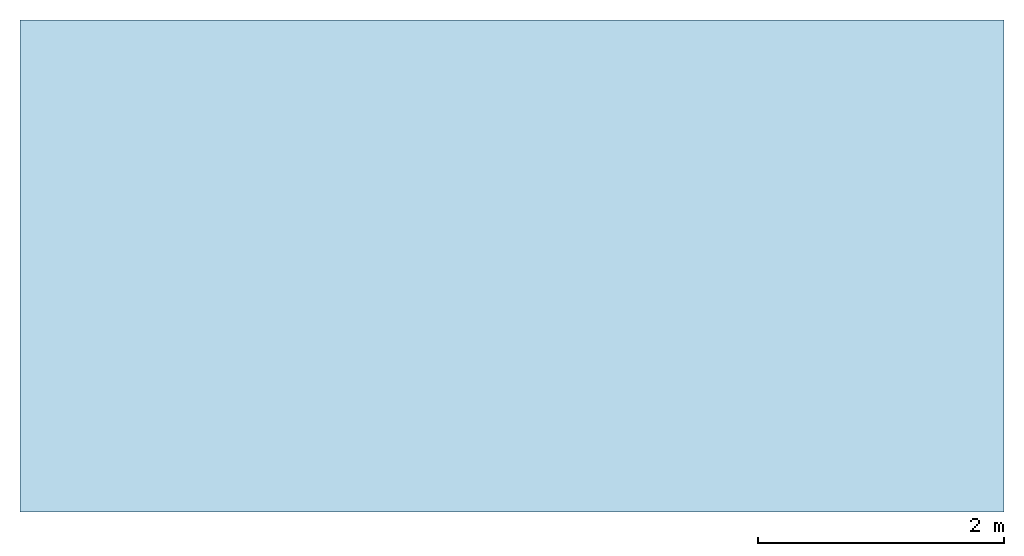
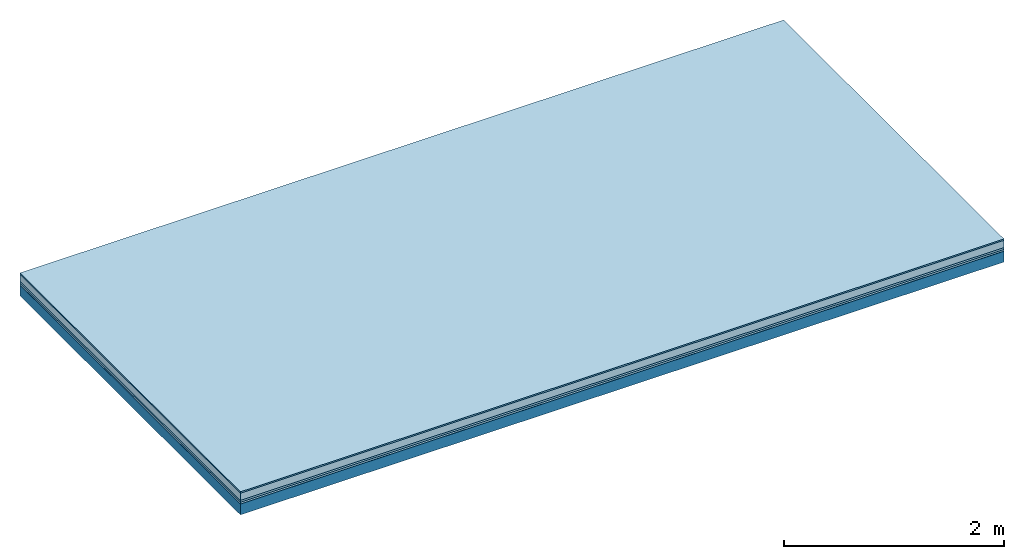
# One storey: 5 plates, 1 member, 1 element without a shape of its own.
"""IFC4 building model written with IfcOpenShell, lengths in metres."""

import ifcopenshell
import ifcopenshell.guid

model = None  # the IFC model being written
_history = None  # IfcOwnerHistory: only IFC2X3 demands one
_inside = {}  # id of a spatial element -> (the spatial element, [elements in it])
_under = {}  # id of a project, library or spatial element -> (it, [spatial elements below it])
_declared = {}  # id of a project -> (the project, [libraries it declares])
_typed = {}  # id of a type object -> (the type object, [elements of that type])
_made_of = {}  # id of a material, layer set ... -> (it, [elements and type objects made of it])


def new_model(schema):
    """Start an empty IFC model of exactly this schema.

    Asked for "IFC4X3", IfcOpenShell would pick the latest addendum, in which some entities
    have other attributes; the version numbers below select the first issue.
    IFC2X3 requires an IfcOwnerHistory on every rooted entity: one is made here for all.
    """
    global model, _history
    if schema == "IFC4X3":
        model = ifcopenshell.file(schema_version=(4, 3, 0, 0))
    else:
        model = ifcopenshell.file(schema=schema)
    _inside.clear()
    _under.clear()
    _declared.clear()
    _typed.clear()
    _made_of.clear()
    _history = None
    if model.schema == "IFC2X3":
        org = make("IfcOrganization", Name="unknown")
        user = make(
            "IfcPersonAndOrganization",
            ThePerson=make("IfcPerson", FamilyName="unknown"),
            TheOrganization=org,
        )
        app = make(
            "IfcApplication",
            ApplicationDeveloper=org,
            Version="unknown",
            ApplicationFullName="unknown",
            ApplicationIdentifier="unknown",
        )
        _history = make(
            "IfcOwnerHistory",
            OwningUser=user,
            OwningApplication=app,
            ChangeAction="ADDED",
            CreationDate=0,
        )
    return model


def make(cls, **values):
    """One entity of the class cls with the attributes given. An attribute that is None is left unset."""
    return model.create_entity(
        cls, **{name: value for name, value in values.items() if value is not None}
    )


def rooted(cls, **values):
    """An entity with a GlobalId (a new one), such as an element, a storey or a relation."""
    return make(cls, GlobalId=ifcopenshell.guid.new(), OwnerHistory=_history, **values)


def si_unit(unit_type, name, prefix=None):
    """IfcSIUnit, for example si_unit("LENGTHUNIT", "METRE", prefix="MILLI")."""
    return make("IfcSIUnit", UnitType=unit_type, Prefix=prefix, Name=name)


def derived_unit(unit_type, elements):
    """IfcDerivedUnit: a product of units, each with its exponent."""
    return make(
        "IfcDerivedUnit",
        Elements=[
            make("IfcDerivedUnitElement", Unit=unit, Exponent=power)
            for unit, power in elements
        ],
        UnitType=unit_type,
    )


def assignment(units):
    """IfcUnitAssignment: the units of a project."""
    return None if units is None else make("IfcUnitAssignment", Units=units)


def point(xyz):
    """IfcCartesianPoint."""
    return None if xyz is None else make("IfcCartesianPoint", Coordinates=xyz)


def direction(xyz):
    """IfcDirection."""
    return None if xyz is None else make("IfcDirection", DirectionRatios=xyz)


def frame(location, z_axis=None, x_axis=None):
    """IfcAxis2Placement3D, a coordinate frame: its origin and axes. An axis left out is left unset."""
    return make(
        "IfcAxis2Placement3D",
        Location=point(location),
        Axis=direction(z_axis),
        RefDirection=direction(x_axis),
    )


def frame_2d(location, x_axis=None):
    """IfcAxis2Placement2D, a coordinate frame in the plane: its origin and x axis."""
    return make(
        "IfcAxis2Placement2D", Location=point(location), RefDirection=direction(x_axis)
    )


def origin():
    """The frame at (0, 0, 0) with its axes left unset."""
    return frame((0.0, 0.0, 0.0))


def origin_with_axes():
    """The frame at (0, 0, 0) with the z axis (0, 0, 1) and the x axis (1, 0, 0) written out."""
    return frame((0.0, 0.0, 0.0), z_axis=(0.0, 0.0, 1.0), x_axis=(1.0, 0.0, 0.0))


def place(relative_to, where):
    """IfcLocalPlacement: puts the frame where relative to a parent placement (None: the world)."""
    return make(
        "IfcLocalPlacement", PlacementRelTo=relative_to, RelativePlacement=where
    )


def context(
    kind, dimensions, precision=None, world=None, true_north=None, identifier=None
):
    """IfcGeometricRepresentationContext, for example the 3D "Model" context."""
    return make(
        "IfcGeometricRepresentationContext",
        ContextIdentifier=identifier,
        ContextType=kind,
        CoordinateSpaceDimension=dimensions,
        Precision=precision,
        WorldCoordinateSystem=world,
        TrueNorth=true_north,
    )


def project(units=None, contexts=None):
    """IfcProject with its units and contexts."""
    return rooted(
        "IfcProject",
        Name="project",
        RepresentationContexts=contexts,
        UnitsInContext=assignment(units),
    )


def spatial(cls, under=None, at=None, **own):
    """A site, building, storey or space (cls), placed at a placement, below another one or the project."""
    s = rooted(cls, ObjectPlacement=at, **own)
    if under is not None:
        _under.setdefault(under.id(), (under, []))[1].append(s)
    return s


def profile(cls, at=None, kind="AREA", **sizes):
    """A parametric profile (cls). Its sizes go by their IFC names, for example OverallWidth=200.0."""
    return make(cls, ProfileType=kind, Position=at, **sizes)


def rectangle(**sizes):
    """IfcRectangleProfileDef."""
    return profile("IfcRectangleProfileDef", **sizes)


def extrude(swept, where, along, depth):
    """IfcExtrudedAreaSolid: the profile swept, set in the frame where, extruded along a direction by depth."""
    return make(
        "IfcExtrudedAreaSolid",
        SweptArea=swept,
        Position=where,
        ExtrudedDirection=direction(along),
        Depth=depth,
    )


def shape(context_of_items, identifier, shape_type, items):
    """IfcShapeRepresentation: the items that make up one representation, for example the "Body"."""
    return make(
        "IfcShapeRepresentation",
        ContextOfItems=context_of_items,
        RepresentationIdentifier=identifier,
        RepresentationType=shape_type,
        Items=items,
    )


def material(Name=None, Category=None):
    """IfcMaterial."""
    return make("IfcMaterial", Name=Name, Category=Category)


def layer(
    of_material, thickness, ventilated=None, Name=None, Category=None, Priority=None
):
    """IfcMaterialLayer: one layer of a wall or slab, of a material (None: an air gap)."""
    return make(
        "IfcMaterialLayer",
        Material=of_material,
        LayerThickness=thickness,
        IsVentilated=ventilated,
        Name=Name,
        Category=Category,
        Priority=Priority,
    )


def layer_set(layers, Name=None):
    """IfcMaterialLayerSet."""
    return make("IfcMaterialLayerSet", MaterialLayers=layers, LayerSetName=Name)


def made_of(thing, what):
    """Note that an element or type object is made of a material, layer set ...; save() writes the relation."""
    if what is not None:
        _made_of.setdefault(what.id(), (what, []))[1].append(thing)
    return thing


def type_object(cls, material=None, **own):
    """A type object (cls), such as IfcWallType, which elements share."""
    return made_of(rooted(cls, **own), material)


def element(
    cls,
    number,
    at=None,
    inside=None,
    cuts=None,
    type_object=None,
    material=None,
    context=None,
    identifier="Body",
    shape_type=None,
    held_by="IfcProductDefinitionShape",
    body=None,
    shapes=None,
    **own,
):
    """One element of the class cls, such as IfcWall. Its Tag is "e" and its number.

    at: its placement. inside: the storey or other place that contains it. cuts: it is an
    opening in that element (IfcRelVoidsElement). A single representation is given by context,
    identifier, shape_type and body (its items); several are given by shapes. held_by: the class
    of the entity that holds the representations. save() writes the other relations.
    """
    e = rooted(cls, Tag="e%d" % number, ObjectPlacement=at, **own)
    if body is not None:
        shapes = [shape(context, identifier, shape_type, body)]
    if shapes is not None:
        e.Representation = make(held_by, Representations=shapes)
    if inside is not None:
        _inside.setdefault(inside.id(), (inside, []))[1].append(e)
    if cuts is not None:
        rooted(
            "IfcRelVoidsElement", RelatingBuildingElement=cuts, RelatedOpeningElement=e
        )
    if type_object is not None:
        _typed.setdefault(type_object.id(), (type_object, []))[1].append(e)
    return made_of(e, material)


def aggregate(whole, parts):
    """IfcRelAggregates: a whole, such as a stair, and the parts it consists of."""
    return rooted("IfcRelAggregates", RelatingObject=whole, RelatedObjects=parts)


def save(model, path):
    """Write the relations noted so far, then the file.

    IfcRelAggregates (storeys below a building ...), IfcRelContainedInSpatialStructure (elements
    in a storey), IfcRelDefinesByType, IfcRelAssociatesMaterial and IfcRelDeclares: one each for
    every whole, place, type object, material and project.
    """
    for whole, parts in _under.values():
        aggregate(whole, parts)
    for where, things in _inside.values():
        rooted(
            "IfcRelContainedInSpatialStructure",
            RelatedElements=things,
            RelatingStructure=where,
        )
    for kind, things in _typed.values():
        rooted("IfcRelDefinesByType", RelatedObjects=things, RelatingType=kind)
    for what, things in _made_of.values():
        rooted("IfcRelAssociatesMaterial", RelatedObjects=things, RelatingMaterial=what)
    for by, libraries in _declared.values():
        rooted("IfcRelDeclares", RelatingContext=by, RelatedDefinitions=libraries)
    model.write(path)


model = new_model("IFC4")

# Units and contexts
plan_context = context("Plan", 3, precision=1e-05, world=origin(), true_north=direction((0.0, 1.0)))
model_context = context("Model", 3, precision=1e-05, world=origin(), true_north=direction((0.0, 1.0)))
ifc_project = project(units=[si_unit("LENGTHUNIT", "METRE"), derived_unit("SOUNDPRESSUREUNIT", [(si_unit("PRESSUREUNIT", "PASCAL", prefix="MICRO"), 0)]), si_unit("ENERGYUNIT", "JOULE", prefix="MEGA"), si_unit("MASSUNIT", "GRAM", prefix="KILO"), derived_unit("THERMALTRANSMITTANCEUNIT", [(si_unit("POWERUNIT", "WATT"), 1), (si_unit("AREAUNIT", "SQUARE_METRE"), -1), (si_unit("THERMODYNAMICTEMPERATUREUNIT", "KELVIN"), -1)]), derived_unit("AREADENSITYUNIT", [(si_unit("MASSUNIT", "GRAM", prefix="KILO"), 1), (si_unit("AREAUNIT", "SQUARE_METRE"), -1)]), derived_unit("USERDEFINED", [(si_unit("ENERGYUNIT", "JOULE", prefix="MEGA"), 1), (si_unit("AREAUNIT", "SQUARE_METRE"), -1)])], contexts=[plan_context, model_context])

# Site, building, storey
site = spatial("IfcSite", under=ifc_project)
building_placement = place(None, origin())
building = spatial("IfcBuilding", under=site, at=building_placement)
storey_placement = place(building_placement, origin())
storey = spatial("IfcBuildingStorey", under=building, at=storey_placement)

# Slab, member, plates
ifc_material_1 = material(Category="11.013")
ifc_layer_1 = layer(ifc_material_1, 0.015, Name="Flooring")
ifc_material_2 = material(Name="Cement screed", Category="04.006")
ifc_layer_2 = layer(ifc_material_2, 0.08, Name="On-material")
ifc_material_3 = material(Name="Wood fiber generic product", Category="10.009")
ifc_layer_3 = layer(ifc_material_3, 0.02, Name="Impact sound insulation")
ifc_material_4 = material()
ifc_layer_4 = layer(ifc_material_4, 0.02, Name="Additional insulation")
ifc_material_5 = material(Name="protection", Category="09.007")
ifc_layer_5 = layer(ifc_material_5, 0.0005, Name="Sub-floor")
ifc_material_6 = material(Name="no composite action")
ifc_layer_6 = layer(ifc_material_6, 0.0, Name="Bond")
ifc_layer_7 = layer(None, 0.12, Name="Supporting structure")
ifc_layer_set = layer_set([ifc_layer_1, ifc_layer_2, ifc_layer_3, ifc_layer_4, ifc_layer_5, ifc_layer_6, ifc_layer_7])
slab_type = type_object("IfcSlabType", Name="A2069", PredefinedType="NOTDEFINED", material=ifc_layer_set)
slab_placement = place(None, frame((0.0, 0.0, 0.0), z_axis=(0.0, 0.0, -1.0), x_axis=(1.0, 0.0, 0.0)))
slab = element("IfcSlab", 1, at=slab_placement, inside=storey, type_object=slab_type, material=ifc_layer_set, Name="Slab #1")
ifc_material_7 = material(Name="Solid timber panel")
member_placement = place(slab_placement, origin())
member = element("IfcMember", 2, at=member_placement, material=ifc_material_7, Name="Supporting structure", context=plan_context, shape_type="SweptSolid", body=[
    extrude(rectangle(XDim=1.0, YDim=0.12, at=frame_2d((0.5, 0.06), x_axis=(1.0, 0.0))), frame((0.0, 4.0, 0.1355), z_axis=(0.0, -1.0, 0.0), x_axis=(1.0, 0.0, 0.0)), (0.0, 0.0, 1.0), 4.0),
    extrude(rectangle(XDim=1.0, YDim=0.12, at=frame_2d((0.5, 0.06), x_axis=(1.0, 0.0))), frame((1.0, 4.0, 0.1355), z_axis=(0.0, -1.0, 0.0), x_axis=(1.0, 0.0, 0.0)), (0.0, 0.0, 1.0), 4.0),
    extrude(rectangle(XDim=1.0, YDim=0.12, at=frame_2d((0.5, 0.06), x_axis=(1.0, 0.0))), frame((2.0, 4.0, 0.1355), z_axis=(0.0, -1.0, 0.0), x_axis=(1.0, 0.0, 0.0)), (0.0, 0.0, 1.0), 4.0),
    extrude(rectangle(XDim=1.0, YDim=0.12, at=frame_2d((0.5, 0.06), x_axis=(1.0, 0.0))), frame((3.0, 4.0, 0.1355), z_axis=(0.0, -1.0, 0.0), x_axis=(1.0, 0.0, 0.0)), (0.0, 0.0, 1.0), 4.0),
    extrude(rectangle(XDim=1.0, YDim=0.12, at=frame_2d((0.5, 0.06), x_axis=(1.0, 0.0))), frame((4.0, 4.0, 0.1355), z_axis=(0.0, -1.0, 0.0), x_axis=(1.0, 0.0, 0.0)), (0.0, 0.0, 1.0), 4.0),
    extrude(rectangle(XDim=1.0, YDim=0.12, at=frame_2d((0.5, 0.06), x_axis=(1.0, 0.0))), frame((5.0, 4.0, 0.1355), z_axis=(0.0, -1.0, 0.0), x_axis=(1.0, 0.0, 0.0)), (0.0, 0.0, 1.0), 4.0),
    extrude(rectangle(XDim=1.0, YDim=0.12, at=frame_2d((0.5, 0.06), x_axis=(1.0, 0.0))), frame((6.0, 4.0, 0.1355), z_axis=(0.0, -1.0, 0.0), x_axis=(1.0, 0.0, 0.0)), (0.0, 0.0, 1.0), 4.0),
    extrude(rectangle(XDim=1.0, YDim=0.12, at=frame_2d((0.5, 0.06), x_axis=(1.0, 0.0))), frame((7.0, 4.0, 0.1355), z_axis=(0.0, -1.0, 0.0), x_axis=(1.0, 0.0, 0.0)), (0.0, 0.0, 1.0), 4.0),
])
plate_1_placement = place(slab_placement, origin())
plate_1 = element("IfcPlate", 3, at=plate_1_placement, material=ifc_material_1, Name="Flooring", context=plan_context, shape_type="SweptSolid", body=[
    extrude(rectangle(XDim=8.0, YDim=4.0, at=frame_2d((4.0, 2.0), x_axis=(1.0, 0.0))), origin_with_axes(), (0.0, 0.0, 1.0), 0.015),
])
plate_2_placement = place(slab_placement, origin())
plate_2 = element("IfcPlate", 4, at=plate_2_placement, material=ifc_material_2, Name="On-material", context=plan_context, shape_type="SweptSolid", body=[
    extrude(rectangle(XDim=8.0, YDim=4.0, at=frame_2d((4.0, 2.0), x_axis=(1.0, 0.0))), frame((0.0, 0.0, 0.015), z_axis=(0.0, 0.0, 1.0), x_axis=(1.0, 0.0, 0.0)), (0.0, 0.0, 1.0), 0.08),
])
plate_3_placement = place(slab_placement, origin())
plate_3 = element("IfcPlate", 5, at=plate_3_placement, material=ifc_material_3, Name="Impact sound insulation", context=plan_context, shape_type="SweptSolid", body=[
    extrude(rectangle(XDim=8.0, YDim=4.0, at=frame_2d((4.0, 2.0), x_axis=(1.0, 0.0))), frame((0.0, 0.0, 0.095), z_axis=(0.0, 0.0, 1.0), x_axis=(1.0, 0.0, 0.0)), (0.0, 0.0, 1.0), 0.02),
])
plate_4_placement = place(slab_placement, origin())
plate_4 = element("IfcPlate", 6, at=plate_4_placement, material=ifc_material_4, Name="Additional insulation", context=plan_context, shape_type="SweptSolid", body=[
    extrude(rectangle(XDim=8.0, YDim=4.0, at=frame_2d((4.0, 2.0), x_axis=(1.0, 0.0))), frame((0.0, 0.0, 0.115), z_axis=(0.0, 0.0, 1.0), x_axis=(1.0, 0.0, 0.0)), (0.0, 0.0, 1.0), 0.02),
])
plate_5_placement = place(slab_placement, origin())
plate_5 = element("IfcPlate", 7, at=plate_5_placement, material=ifc_material_5, Name="Sub-floor", context=plan_context, shape_type="SweptSolid", body=[
    extrude(rectangle(XDim=8.0, YDim=4.0, at=frame_2d((4.0, 2.0), x_axis=(1.0, 0.0))), frame((0.0, 0.0, 0.135), z_axis=(0.0, 0.0, 1.0), x_axis=(1.0, 0.0, 0.0)), (0.0, 0.0, 1.0), 0.0005),
])
aggregate(slab, [plate_1, plate_2, plate_3, plate_4, plate_5, member])

save(model, "model.ifc")
